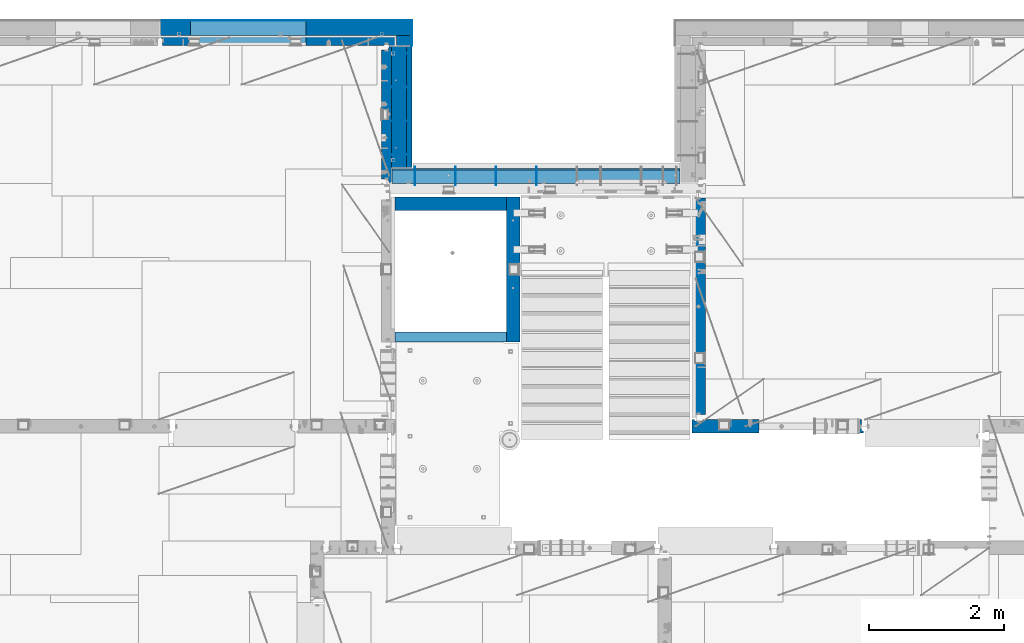
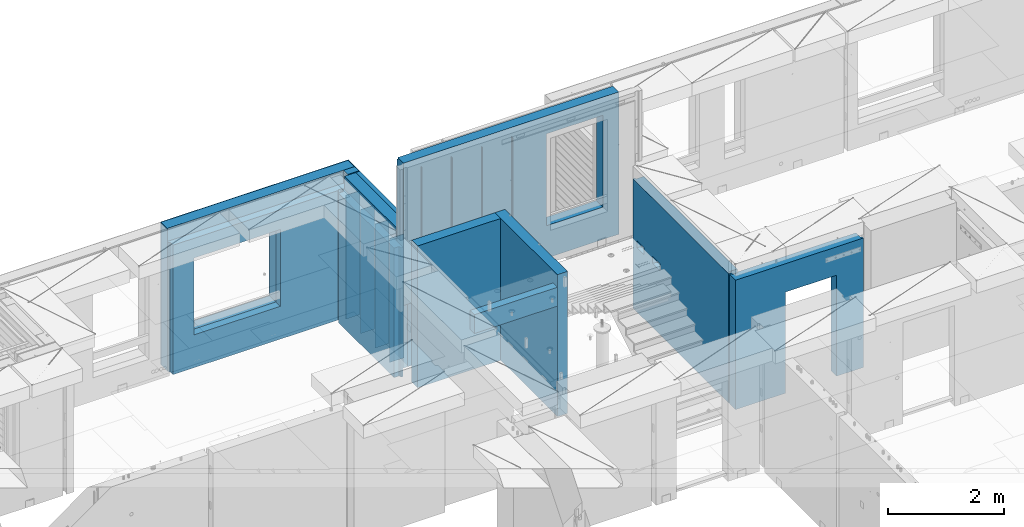
# One storey, part 229 of 341: 22 walls, 7 elements without a shape of their own.
"""IFC2X3 building model written with IfcOpenShell, lengths in millimetres."""

from ifc_helpers import new_model, si_unit, frame, origin_with_axes, place, context, subcontext, project, spatial, faceted_brep, material, type_object, element, aggregate, save


model = new_model("IFC2X3")

# Units and contexts
model_context = context("Model", 3, precision=1e-05, world=origin_with_axes())
body_context = subcontext(model_context, "Body", "Model", "MODEL_VIEW")
ifc_project = project(units=[si_unit("LENGTHUNIT", "METRE", prefix="MILLI"), si_unit("AREAUNIT", "SQUARE_METRE"), si_unit("VOLUMEUNIT", "CUBIC_METRE"), si_unit("MASSUNIT", "GRAM", prefix="KILO"), si_unit("TIMEUNIT", "SECOND"), si_unit("PLANEANGLEUNIT", "RADIAN"), si_unit("SOLIDANGLEUNIT", "STERADIAN"), si_unit("THERMODYNAMICTEMPERATUREUNIT", "DEGREE_CELSIUS"), si_unit("LUMINOUSINTENSITYUNIT", "LUMEN")], contexts=[model_context])

# Site, building, storey
site_placement = place(None, origin_with_axes())
site = spatial("IfcSite", under=ifc_project, at=site_placement, CompositionType="ELEMENT")
building_placement = place(site_placement, origin_with_axes())
building = spatial("IfcBuilding", under=site, at=building_placement, CompositionType="ELEMENT")
storey_placement = place(building_placement, origin_with_axes())
storey = spatial("IfcBuildingStorey", under=building, at=storey_placement, Name="5", CompositionType="ELEMENT", Elevation=0.0)

# Assembly, walls
assembly_1_placement = place(storey_placement, origin_with_axes())
assembly_1 = element("IfcElementAssembly", 1, at=assembly_1_placement, inside=storey, AssemblyPlace="NOTDEFINED", PredefinedType="REINFORCEMENT_UNIT")
ifc_material_1 = material(Name="Undefined")
wall_type_1 = type_object("IfcWallType", PredefinedType="NOTDEFINED")
wall_1_placement = place(assembly_1_placement, frame((17730.0, 21005.0, 95115.0), z_axis=(0.0, 0.0, 1.0), x_axis=(1.0, 0.0, 0.0)))
wall_1 = element("IfcWall", 2, at=wall_1_placement, type_object=wall_type_1, material=ifc_material_1, Name="(PD)", context=body_context, shape_type="Brep", body=[
    faceted_brep([(0.0, 5.0, -1300.0), (0.0, 5.0, 1300.0), (280.0, 5.0, 1300.0), (280.0, 5.0, -1300.0), (0.0, -5.0, 1300.0), (280.0, -5.0, 1300.0), (0.0, -5.0, -1300.0), (280.0, -5.0, -1300.0)], [[[0, 1, 2, 3]], [[1, 4, 5, 2]], [[4, 6, 7, 5]], [[6, 0, 3, 7]], [[5, 7, 3, 2]], [[6, 4, 1, 0]]]),
])
wall_2_placement = place(assembly_1_placement, frame((17730.0, 21505.0, 95115.0), z_axis=(0.0, 0.0, 1.0), x_axis=(1.0, 0.0, 0.0)))
wall_2 = element("IfcWall", 3, at=wall_2_placement, type_object=wall_type_1, material=ifc_material_1, Name="(PD)", context=body_context, shape_type="Brep", body=[
    faceted_brep([(0.0, 5.0, -1300.0), (0.0, 5.0, 1300.0), (280.0, 5.0, 1300.0), (280.0, 5.0, -1300.0), (0.0, -5.0, 1300.0), (280.0, -5.0, 1300.0), (0.0, -5.0, -1300.0), (280.0, -5.0, -1300.0)], [[[0, 1, 2, 3]], [[1, 4, 5, 2]], [[4, 6, 7, 5]], [[6, 0, 3, 7]], [[5, 7, 3, 2]], [[6, 4, 1, 0]]]),
])
wall_3_placement = place(assembly_1_placement, frame((17730.0, 22005.0, 95115.0), z_axis=(0.0, 0.0, 1.0), x_axis=(1.0, 0.0, 0.0)))
wall_3 = element("IfcWall", 4, at=wall_3_placement, type_object=wall_type_1, material=ifc_material_1, Name="(PD)", context=body_context, shape_type="Brep", body=[
    faceted_brep([(0.0, 5.0, -1300.0), (0.0, 5.0, 1300.0), (280.0, 5.0, 1300.0), (280.0, 5.0, -1300.0), (0.0, -5.0, 1300.0), (280.0, -5.0, 1300.0), (0.0, -5.0, -1300.0), (280.0, -5.0, -1300.0)], [[[0, 1, 2, 3]], [[1, 4, 5, 2]], [[4, 6, 7, 5]], [[6, 0, 3, 7]], [[5, 7, 3, 2]], [[6, 4, 1, 0]]]),
])

assembly_2_placement = place(storey_placement, origin_with_axes())
assembly_2 = element("IfcElementAssembly", 5, at=assembly_2_placement, inside=storey, AssemblyPlace="NOTDEFINED", PredefinedType="REINFORCEMENT_UNIT")
wall_4_placement = place(assembly_2_placement, frame((18110.0002441406, 20550.0, 96745.0), z_axis=(0.0, 0.0, 1.0), x_axis=(0.0, 1.0, 0.0)))
wall_4 = element("IfcWall", 6, at=wall_4_placement, type_object=wall_type_1, material=ifc_material_1, Name="(PD)", context=body_context, shape_type="Brep", body=[
    faceted_brep([(0.0, 5.0, -1300.0), (0.0, 5.0, 1300.0), (280.0, 5.0, 1300.0), (280.0, 5.0, -1300.0), (0.0, -5.0, 1300.0), (280.0, -5.0, 1300.0), (0.0, -5.0, -1300.0), (280.0, -5.0, -1300.0)], [[[0, 1, 2, 3]], [[1, 4, 5, 2]], [[4, 6, 7, 5]], [[6, 0, 3, 7]], [[5, 7, 3, 2]], [[6, 4, 1, 0]]]),
])
wall_5_placement = place(assembly_2_placement, frame((18710.0002441406, 20550.0, 96745.0), z_axis=(0.0, 0.0, 1.0), x_axis=(0.0, 1.0, 0.0)))
wall_5 = element("IfcWall", 7, at=wall_5_placement, type_object=wall_type_1, material=ifc_material_1, Name="(PD)", context=body_context, shape_type="Brep", body=[
    faceted_brep([(0.0, 5.0, -1300.0), (0.0, 5.0, 1300.0), (280.0, 5.0, 1300.0), (280.0, 5.0, -1300.0), (0.0, -5.0, 1300.0), (280.0, -5.0, 1300.0), (0.0, -5.0, -1300.0), (280.0, -5.0, -1300.0)], [[[0, 1, 2, 3]], [[1, 4, 5, 2]], [[4, 6, 7, 5]], [[6, 0, 3, 7]], [[5, 7, 3, 2]], [[6, 4, 1, 0]]]),
])
wall_6_placement = place(assembly_2_placement, frame((19310.0002441406, 20550.0, 96745.0), z_axis=(0.0, 0.0, 1.0), x_axis=(0.0, 1.0, 0.0)))
wall_6 = element("IfcWall", 8, at=wall_6_placement, type_object=wall_type_1, material=ifc_material_1, Name="(PD)", context=body_context, shape_type="Brep", body=[
    faceted_brep([(0.0, 5.0, -1300.0), (0.0, 5.0, 1300.0), (280.0, 5.0, 1300.0), (280.0, 5.0, -1300.0), (0.0, -5.0, 1300.0), (280.0, -5.0, 1300.0), (0.0, -5.0, -1300.0), (280.0, -5.0, -1300.0)], [[[0, 1, 2, 3]], [[1, 4, 5, 2]], [[4, 6, 7, 5]], [[6, 0, 3, 7]], [[5, 7, 3, 2]], [[6, 4, 1, 0]]]),
])
wall_7_placement = place(assembly_2_placement, frame((19910.0002441406, 20550.0, 96745.0), z_axis=(0.0, 0.0, 1.0), x_axis=(0.0, 1.0, 0.0)))
wall_7 = element("IfcWall", 9, at=wall_7_placement, type_object=wall_type_1, material=ifc_material_1, Name="(PD)", context=body_context, shape_type="Brep", body=[
    faceted_brep([(0.0, 5.0, -1300.0), (0.0, 5.0, 1300.0), (280.0, 5.0, 1300.0), (280.0, 5.0, -1300.0), (0.0, -5.0, 1300.0), (280.0, -5.0, 1300.0), (0.0, -5.0, -1300.0), (280.0, -5.0, -1300.0)], [[[0, 1, 2, 3]], [[1, 4, 5, 2]], [[4, 6, 7, 5]], [[6, 0, 3, 7]], [[5, 7, 3, 2]], [[6, 4, 1, 0]]]),
])

# Wall
wall_8_placement = place(assembly_1_placement, frame((17730.0, 22505.0, 95115.0), z_axis=(0.0, 0.0, 1.0), x_axis=(1.0, 0.0, 0.0)))
wall_8 = element("IfcWall", 10, at=wall_8_placement, type_object=wall_type_1, material=ifc_material_1, Name="(PD)", context=body_context, shape_type="Brep", body=[
    faceted_brep([(0.0, 5.0, -1300.0), (0.0, 5.0, 1300.0), (280.0, 5.0, 1300.0), (280.0, 5.0, -1300.0), (0.0, -5.0, 1300.0), (280.0, -5.0, 1300.0), (0.0, -5.0, -1300.0), (280.0, -5.0, -1300.0)], [[[0, 1, 2, 3]], [[1, 4, 5, 2]], [[4, 6, 7, 5]], [[6, 0, 3, 7]], [[5, 7, 3, 2]], [[6, 4, 1, 0]]]),
])

# Assembly, wall
assembly_3_placement = place(storey_placement, origin_with_axes())
assembly_3 = element("IfcElementAssembly", 11, at=assembly_3_placement, inside=storey, AssemblyPlace="NOTDEFINED", PredefinedType="REINFORCEMENT_UNIT")
ifc_material_2 = material(Name="CONCRETE/C25/30")
wall_type_2 = type_object("IfcWallType", PredefinedType="NOTDEFINED")
wall_9_placement = place(assembly_3_placement, frame((22310.0, 16980.0, 95112.5), z_axis=(0.0, 0.0, 1.0), x_axis=(1.0, 0.0, 0.0)))
wall_9 = element("IfcWall", 12, at=wall_9_placement, type_object=wall_type_2, material=ifc_material_2, context=body_context, shape_type="Brep", body=[
    faceted_brep([(890.000686645508, 100.0, 762.5), (890.000686645508, -100.0, 762.5), (890.000686645508, -100.0, -1357.5), (890.000686645508, 100.0, -1357.5), (1910.00068664551, 100.0, 762.5), (1910.00068664551, -100.0, 762.5), (1910.00068664551, 100.0, -1357.5), (1910.00068664551, -100.0, -1357.5), (-100.0, -100.0, -1357.5), (-100.0, -100.0, 1357.5), (-100.0, 100.0, 1357.5), (-100.0, 100.0, -1357.5), (2440.0, -100.0, 1357.5), (2440.0, -100.0, -1357.5), (2440.0, -70.0000000000036, -1357.5), (2440.0, -70.0000000000036, 1357.5), (2410.0, 100.0, 1357.5), (2410.0, -57.0, 1357.5), (2410.0, -57.0, -1357.5), (2410.0, 100.0, -1357.5), (65.0000000000036, 100.0, 1357.5), (52.0, 80.0, 1357.5), (-52.0, 80.0, 1357.5), (-65.0, 100.0, 1357.5), (-65.0, 100.0, -1357.5), (-52.0, 80.0, -1357.5), (52.0, 80.0, -1357.5), (65.0000000000036, 100.0, -1357.5)], [[[0, 1, 2, 3]], [[4, 5, 1, 0]], [[6, 7, 5, 4]], [[8, 9, 10, 11]], [[12, 13, 14, 15]], [[16, 17, 18, 19]], [[15, 14, 18, 17]], [[16, 20, 21, 22, 23, 10, 9, 12, 15, 17]], [[11, 10, 23, 24]], [[22, 25, 24, 23]], [[21, 26, 25, 22]], [[20, 27, 26, 21]], [[8, 11, 24, 25, 26, 27, 3, 2]], [[13, 12, 9, 8, 2, 1, 5, 7]], [[19, 18, 14, 13, 7, 6]], [[3, 27, 20, 16, 19, 6, 4, 0]]]),
])
aggregate(assembly_3, [wall_9])

assembly_4_placement = place(storey_placement, origin_with_axes())
assembly_4 = element("IfcElementAssembly", 13, at=assembly_4_placement, inside=storey, AssemblyPlace="NOTDEFINED", PredefinedType="REINFORCEMENT_UNIT")
wall_10_placement = place(assembly_4_placement, frame((22310.0, 16980.0, 95112.5), z_axis=(0.0, 0.0, 1.0), x_axis=(0.0, 1.0, 0.0)))
wall_10 = element("IfcWall", 14, at=wall_10_placement, type_object=wall_type_2, material=ifc_material_2, context=body_context, shape_type="Brep", body=[
    faceted_brep([(3059.9952678883, 0.0998642726626713, 102.5), (3259.9952678883, 0.0998642726626713, 102.5), (3259.9952678883, 0.0998642726626713, -7.5), (3059.9952678883, 0.0998642726626713, -7.5), (3034.9952678883, 100.099864272663, -7.5), (3284.9952678883, 100.099864272663, -7.5), (3034.9952678883, 100.099864272663, 137.5), (3284.9952678883, 100.099864272663, 137.5), (3420.0, 70.0, 1357.5), (3420.0, 100.0, 1357.5), (130.0, 100.0, 1357.5), (130.0, 70.0, 1357.5), (180.0, 57.0, 1357.5), (180.0, -100.0, 1357.5), (3384.99999178648, -100.000000948603, 1357.5), (3385.00000172571, 57.0000007519884, 1357.5), (130.0, 100.0, -1357.5), (130.0, 70.0, -1357.5), (180.0, 57.0, -1357.5), (180.0, -100.0, -1357.5), (3384.99999178648, -100.0, -1357.5), (3385.00000172571, 57.0000007519884, -1357.5), (3420.0, 100.0, -1357.5), (3420.0, 70.0, -1357.5), (2519.9952678883, 0.0998642726626713, 102.5), (2719.9952678883, 0.0998642726626713, 102.5), (2719.9952678883, 0.0998642726626713, -7.5), (2519.9952678883, 0.0998642726626713, -7.5), (2744.9952678883, 100.099864272663, -7.5), (2744.9952678883, 100.099864272663, 137.5), (2494.9952678883, 100.099864272663, -7.5), (2494.9952678883, 100.099864272663, 137.5)], [[[0, 1, 2, 3]], [[4, 3, 2, 5]], [[6, 0, 3, 4]], [[7, 1, 0, 6]], [[5, 2, 1, 7]], [[8, 9, 10, 11, 12, 13, 14, 15]], [[10, 16, 17, 11]], [[11, 17, 18, 12]], [[13, 12, 18, 19]], [[13, 19, 20, 14]], [[14, 20, 21, 15]], [[19, 18, 17, 16, 22, 23, 21, 20]], [[15, 21, 23, 8]], [[22, 9, 8, 23]], [[24, 25, 26, 27]], [[28, 26, 25, 29]], [[30, 27, 26, 28]], [[31, 24, 27, 30]], [[29, 25, 24, 31]], [[16, 10, 9, 22], [4, 5, 7, 6], [30, 28, 29, 31]]]),
])
aggregate(assembly_4, [wall_10])

# Assembly
assembly_5_placement = place(assembly_2_placement, origin_with_axes())
assembly_5 = element("IfcElementAssembly", 15, at=assembly_5_placement, Name="Steel Assembly", AssemblyPlace="NOTDEFINED", PredefinedType="NOTDEFINED")

aggregate(assembly_2, [assembly_5, wall_4, wall_5, wall_6, wall_7])

# Wall
ifc_material_3 = material(Name="COS5gt")
wall_type_3 = type_object("IfcWallType", PredefinedType="NOTDEFINED")
wall_11_placement = place(assembly_5_placement, frame((17765.0, 20690.0, 96747.5), z_axis=(0.0, 0.0, 1.0), x_axis=(1.0, 0.0, 0.0)))
wall_11 = element("IfcWall", 16, at=wall_11_placement, type_object=wall_type_3, material=ifc_material_3, context=body_context, shape_type="Brep", body=[
    faceted_brep([(0.0, -110.0, 1492.5), (4270.0, -110.0, 1492.5), (4270.0, 90.0, 1492.5), (0.0, 90.0, 1492.5), (4270.0, 110.0, 1442.5), (4270.0, 90.0, 1442.5), (4270.0, -110.0, -1492.5), (4270.0, 90.0, -1492.5), (4270.0, 90.0, -1442.5), (4270.0, 110.0, -1442.5), (0.0, 110.0, 1442.5), (0.0, 110.0, -1442.5), (2839.99840497971, 109.999997720995, -802.5), (2839.99840497971, 109.999997720995, -807.5), (2869.99840497971, 109.999997720995, -807.5), (3919.99840497971, 109.999997720995, -807.5), (3949.99840497971, 109.999997720995, -807.5), (3949.99840497971, 109.999997720995, -802.5), (3949.99840497971, 109.999997720995, 1107.5), (2839.99840497971, 109.999997720995, 1107.5), (2834.05245909535, -110.0, 1113.44594588435), (3955.94435086406, -110.0, 1113.44594588435), (2834.05245909535, -110.0, -813.445945884348), (3955.94435086406, -110.0, -813.445945884348), (0.0, -110.0, -1492.5), (0.0, 90.0, -1492.5), (0.0, 90.0, -1442.5), (0.0, 90.0, 1442.5)], [[[0, 1, 2, 3]], [[4, 5, 2, 1, 6, 7, 8, 9]], [[10, 4, 9, 11], [12, 13, 14, 15, 16, 17, 18, 19]], [[20, 19, 18, 21]], [[12, 19, 20, 22, 13]], [[23, 16, 15, 14, 13, 22]], [[21, 18, 17, 16, 23]], [[0, 24, 6, 1], [22, 20, 21, 23]], [[6, 24, 25, 7]], [[7, 25, 26, 8]], [[9, 8, 26, 11]], [[25, 24, 0, 3, 27, 10, 11, 26]], [[2, 5, 27, 3]], [[4, 10, 27, 5]]]),
])

aggregate(assembly_5, [wall_11])

wall_12_placement = place(assembly_1_placement, frame((17870.0, 22605.0, 95247.5), z_axis=(0.0, 0.0, 1.0), x_axis=(0.0, -1.0, 0.0)))
wall_12 = element("IfcWall", 17, at=wall_12_placement, type_object=wall_type_3, material=ifc_material_3, context=body_context, shape_type="Brep", body=[
    faceted_brep([(0.0, 110.0, -1492.5), (0.0, 110.0, 1492.5), (1790.0, 110.0, 1492.5), (1790.0, 110.0, -1492.5), (0.0, -110.0, 1492.5), (1790.0, -110.0, 1492.5), (0.0, -110.0, -1492.5), (1790.0, -110.0, -1492.5)], [[[0, 1, 2, 3]], [[1, 4, 5, 2]], [[4, 6, 7, 5]], [[6, 0, 3, 7]], [[5, 7, 3, 2]], [[6, 4, 1, 0]]]),
])

# Assembly, walls
assembly_6_placement = place(storey_placement, origin_with_axes())
assembly_6 = element("IfcElementAssembly", 18, at=assembly_6_placement, inside=storey, AssemblyPlace="NOTDEFINED", PredefinedType="REINFORCEMENT_UNIT")
ifc_material_4 = material()
wall_13_placement = place(assembly_6_placement, frame((17945.0, 22770.0, 95247.5), z_axis=(0.0, 0.0, 1.0), x_axis=(0.0, -1.0, 0.0)))
wall_13 = element("IfcWall", 19, at=wall_13_placement, type_object=wall_type_3, material=ifc_material_4, context=body_context, shape_type="Brep", body=[
    faceted_brep([(0.0, 110.0, -1492.5), (0.0, 110.0, 1492.5), (150.0, 110.0, 1492.5), (150.0, 110.0, -1492.5), (0.0, -110.0, 1492.5), (150.0, -110.0, 1492.5), (0.0, -110.0, -1492.5), (150.0, -110.0, -1492.5)], [[[0, 1, 2, 3]], [[1, 4, 5, 2]], [[4, 6, 7, 5]], [[6, 0, 3, 7]], [[5, 7, 3, 2]], [[6, 4, 1, 0]]]),
])
wall_14_placement = place(assembly_6_placement, frame((14340.0, 22880.0, 95247.5), z_axis=(0.0, 0.0, 1.0), x_axis=(1.0, 0.0, 0.0)))
wall_14 = element("IfcWall", 20, at=wall_14_placement, type_object=wall_type_3, material=ifc_material_4, context=body_context, shape_type="Brep", body=[
    faceted_brep([(0.0, -110.0, -1492.5), (0.0, 110.0, -1492.5), (3715.0, 110.0, -1492.5), (3715.0, -110.0, -1492.5), (0.0, -110.0, 1492.5), (0.0, 110.0, 1492.5), (3715.0, -110.0, 1492.5), (3715.0, 110.0, 1492.5), (444.999710731721, 110.0, -802.5), (2154.99971073172, 110.0, -802.5), (2154.99971073172, 110.0, 807.5), (444.999710731721, 110.0, 807.5), (444.999710731721, -110.0, -802.5), (444.999710731721, -110.0, 807.5), (2154.99971073172, -110.0, 807.5), (2154.99971073172, -110.0, -802.5)], [[[0, 1, 2, 3]], [[0, 4, 5, 1]], [[5, 4, 6, 7]], [[1, 5, 7, 2], [8, 9, 10, 11]], [[6, 3, 2, 7]], [[4, 0, 3, 6], [12, 13, 14, 15]], [[10, 14, 13, 11]], [[9, 15, 14, 10]], [[8, 12, 15, 9]], [[11, 13, 12, 8]]]),
])

# Wall
ifc_material_5 = material(Name="CONCRETE/C30/37")
wall_type_4 = type_object("IfcWallType", PredefinedType="NOTDEFINED")
wall_15_placement = place(assembly_1_placement, frame((18022.5, 22620.0, 95247.5), z_axis=(0.0, 0.0, 1.0), x_axis=(0.0, -1.0, 0.0)))
wall_15 = element("IfcWall", 21, at=wall_15_placement, type_object=wall_type_4, material=ifc_material_5, context=body_context, shape_type="Brep", body=[
    faceted_brep([(15.0, 42.5, 1342.99999994476), (15.0, 32.4999992506928, 1344.9999999992), (1805.0, 32.5, 1345.0), (1805.0, 42.5, 1343.0), (15.0, 32.4999991126933, 1355.00000040043), (1805.0, 32.5, 1355.0), (15.0, 42.5, 1356.99999988925), (1805.0, 42.5, 1357.0), (15.0, 42.5, 1206.99999988925), (1805.0, 42.5, 1207.0), (1805.0, 32.5, 1205.0), (15.0000000000009, 32.4999991126933, 1205.00000040043), (1805.0, 32.5, 1195.0), (15.0000000000009, 32.4999992506928, 1194.9999999992), (15.0, 42.5, 1192.99999994476), (1805.0, 42.5, 1193.0), (1805.0, 42.5, 1057.0), (15.0, 42.5, 1056.99999988925), (1805.0, 32.5, 1055.0), (15.0, 32.4999991126933, 1055.00000040043), (1805.0, 32.5, 1045.0), (15.0, 32.4999992506928, 1044.9999999992), (15.0, 42.5, 1042.99999994476), (1805.0, 42.5, 1043.0), (1805.0, 42.5, 907.0), (15.0, 42.5, 906.999999889245), (1805.0, 32.5, 905.0), (15.0, 32.4999991126933, 905.000000400425), (1805.0, 32.5, 895.0), (15.0, 32.4999992506928, 894.9999999992), (15.0, 42.5, 892.999999944761), (1805.0, 42.5, 893.0), (1805.0, 42.5, 757.0), (15.0, 42.5, 756.999999889245), (1805.0, 32.5, 755.0), (15.0, 32.4999991126933, 755.000000400425), (1805.0, 32.5, 745.0), (15.0, 32.4999992506928, 744.9999999992), (15.0, 42.5, 742.999999944761), (1805.0, 42.5, 743.0), (1805.0, 42.5, 607.0), (15.0, 42.5, 606.999999889245), (1805.0, 32.5, 605.0), (15.0, 32.4999991126933, 605.000000400425), (1805.0, 32.5, 595.0), (15.0, 32.4999992506928, 594.9999999992), (15.0, 42.5, 592.999999944761), (1805.0, 42.5, 593.0), (1805.0, 42.5, 457.0), (15.0, 42.5, 456.999999889245), (1805.0, 32.5, 455.0), (15.0, 32.4999991126933, 455.000000400425), (1805.0, 32.5, 445.0), (15.0, 32.4999992506928, 444.9999999992), (15.0, 42.5, 442.999999944761), (1805.0, 42.5, 443.0), (1805.0, 42.5, 307.0), (15.0, 42.5, 306.999999889245), (1805.0, 32.5, 305.0), (15.0, 32.4999991126933, 305.000000400425), (1805.0, 32.5, 295.0), (15.0, 32.4999992506928, 294.9999999992), (15.0, 42.5, 292.999999944761), (1805.0, 42.5, 293.0), (1805.0, 42.5, 157.0), (15.0, 42.5, 156.999999889245), (1805.0, 32.5, 155.0), (15.0000000000009, 32.4999991126933, 155.000000400425), (1805.0, 32.5, 145.0), (15.0000000000009, 32.4999992506928, 144.9999999992), (15.0, 42.5, 142.999999944761), (1805.0, 42.5, 143.0), (1805.0, 42.5, 7.0), (15.0, 42.5, 6.99999988924537), (1805.0, 32.5, 5.0), (14.9999999999991, 32.4999991126933, 5.00000040042505), (1805.0, 32.5, -5.0), (14.9999999999991, 32.4999992506928, -5.00000000080036), (15.0, 42.5, -7.00000005523907), (1805.0, 42.5, -7.0), (1805.0, 42.5, -143.0), (15.0, 42.5, -143.000000110755), (1805.0, 32.5, -145.0), (15.0000000000009, 32.4999991126933, -144.999999599575), (1805.0, 32.5, -155.0), (15.0000000000009, 32.4999992506928, -155.0000000008), (15.0, 42.5, -157.000000055239), (1805.0, 42.5, -157.0), (1805.0, 42.5, -293.0), (15.0, 42.5, -293.000000110755), (1805.0, 32.5, -295.0), (15.0, 32.4999991126933, -294.999999599575), (1805.0, 32.5, -305.0), (15.0, 32.4999992506928, -305.0000000008), (15.0, 42.5, -307.000000055239), (1805.0, 42.5, -307.0), (1805.0, 42.5, -443.0), (15.0, 42.5, -443.000000110755), (1805.0, 32.5, -445.0), (15.0000000000009, 32.4999991126933, -444.999999599575), (1805.0, 32.5, -455.0), (15.0000000000009, 32.4999992506928, -455.0000000008), (15.0, 42.5, -457.000000055239), (1805.0, 42.5, -457.0), (1805.0, 42.5, -593.0), (15.0, 42.5, -593.000000110755), (1805.0, 32.5, -595.0), (15.0, 32.4999991126933, -594.999999599575), (1805.0, 32.5, -605.0), (15.0, 32.4999992506928, -605.0000000008), (15.0, 42.5, -607.000000055239), (1805.0, 42.5, -607.0), (1805.0, 42.5, -743.0), (15.0, 42.5, -743.000000110755), (1805.0, 32.5, -745.0), (15.0, 32.4999991126933, -744.999999599575), (1805.0, 32.5, -755.0), (15.0, 32.4999992506928, -755.0000000008), (15.0, 42.5, -757.000000055239), (1805.0, 42.5, -757.0), (1805.0, 42.5, -893.0), (15.0, 42.5, -893.000000110755), (1805.0, 32.5, -895.0), (15.0000000000009, 32.4999991126933, -894.999999599575), (1805.0, 32.5, -905.0), (15.0000000000009, 32.4999992506928, -905.0000000008), (15.0, 42.5, -907.000000055239), (1805.0, 42.5, -907.0), (1805.0, 42.5, -1043.0), (15.0, 42.5, -1043.00000011075), (1805.0, 32.5, -1045.0), (15.0, 32.4999991126933, -1044.99999959957), (1805.0, 32.5, -1055.0), (15.0, 32.4999992506928, -1055.0000000008), (15.0, 42.5, -1057.00000005524), (1805.0, 42.5, -1057.0), (1805.0, 42.5, -1193.0), (15.0, 42.5, -1193.00000011075), (1805.0, 32.5, -1195.0), (15.0, 32.4999991126933, -1194.99999959957), (1805.0, 32.5, -1205.0), (15.0, 32.4999992506928, -1205.0000000008), (15.0, 42.5, -1207.00000005524), (1805.0, 42.5, -1207.0), (1805.0, 42.5, -1343.0), (15.0, 42.5, -1343.00000011075), (1805.0, 32.5, -1345.0), (15.0, 32.4999991126933, -1344.99999959957), (1805.0, 32.5, -1355.0), (15.0, 32.4999992506928, -1355.0000000008), (15.0, 42.5, -1357.00000005524), (1805.0, 42.5, -1357.0), (1805.0, 42.5, -1492.5), (15.0, 42.5, -1492.5), (15.0, -42.5, -1492.5), (1805.0, -42.5, -1492.5), (15.0, -42.5, 1492.5), (1805.0, -42.5, 1492.5), (15.0, 42.5, 1492.5), (1805.0, 42.5, 1492.5)], [[[0, 1, 2, 3]], [[4, 5, 2, 1]], [[6, 7, 5, 4]], [[8, 9, 10, 11]], [[11, 10, 12, 13]], [[14, 13, 12, 15]], [[16, 17, 14, 15]], [[17, 16, 18, 19]], [[19, 18, 20, 21]], [[22, 21, 20, 23]], [[24, 25, 22, 23]], [[25, 24, 26, 27]], [[27, 26, 28, 29]], [[30, 29, 28, 31]], [[32, 33, 30, 31]], [[33, 32, 34, 35]], [[35, 34, 36, 37]], [[38, 37, 36, 39]], [[40, 41, 38, 39]], [[41, 40, 42, 43]], [[43, 42, 44, 45]], [[46, 45, 44, 47]], [[48, 49, 46, 47]], [[49, 48, 50, 51]], [[51, 50, 52, 53]], [[54, 53, 52, 55]], [[56, 57, 54, 55]], [[57, 56, 58, 59]], [[59, 58, 60, 61]], [[62, 61, 60, 63]], [[64, 65, 62, 63]], [[65, 64, 66, 67]], [[67, 66, 68, 69]], [[70, 69, 68, 71]], [[72, 73, 70, 71]], [[73, 72, 74, 75]], [[75, 74, 76, 77]], [[78, 77, 76, 79]], [[80, 81, 78, 79]], [[81, 80, 82, 83]], [[83, 82, 84, 85]], [[86, 85, 84, 87]], [[88, 89, 86, 87]], [[89, 88, 90, 91]], [[91, 90, 92, 93]], [[94, 93, 92, 95]], [[96, 97, 94, 95]], [[97, 96, 98, 99]], [[99, 98, 100, 101]], [[102, 101, 100, 103]], [[104, 105, 102, 103]], [[105, 104, 106, 107]], [[107, 106, 108, 109]], [[110, 109, 108, 111]], [[112, 113, 110, 111]], [[113, 112, 114, 115]], [[115, 114, 116, 117]], [[118, 117, 116, 119]], [[120, 121, 118, 119]], [[121, 120, 122, 123]], [[123, 122, 124, 125]], [[126, 125, 124, 127]], [[128, 129, 126, 127]], [[129, 128, 130, 131]], [[131, 130, 132, 133]], [[134, 133, 132, 135]], [[136, 137, 134, 135]], [[137, 136, 138, 139]], [[139, 138, 140, 141]], [[142, 141, 140, 143]], [[144, 145, 142, 143]], [[145, 144, 146, 147]], [[147, 146, 148, 149]], [[150, 149, 148, 151]], [[152, 153, 150, 151]], [[154, 153, 152, 155]], [[156, 154, 155, 157]], [[158, 156, 157, 159]], [[1, 0, 8, 11, 13, 14, 17, 19, 21, 22, 25, 27, 29, 30, 33, 35, 37, 38, 41, 43, 45, 46, 49, 51, 53, 54, 57, 59, 61, 62, 65, 67, 69, 70, 73, 75, 77, 78, 81, 83, 85, 86, 89, 91, 93, 94, 97, 99, 101, 102, 105, 107, 109, 110, 113, 115, 117, 118, 121, 123, 125, 126, 129, 131, 133, 134, 137, 139, 141, 142, 145, 147, 149, 150, 153, 154, 156, 158, 6, 4]], [[9, 8, 0, 3]], [[159, 157, 155, 152, 151, 148, 146, 144, 143, 140, 138, 136, 135, 132, 130, 128, 127, 124, 122, 120, 119, 116, 114, 112, 111, 108, 106, 104, 103, 100, 98, 96, 95, 92, 90, 88, 87, 84, 82, 80, 79, 76, 74, 72, 71, 68, 66, 64, 63, 60, 58, 56, 55, 52, 50, 48, 47, 44, 42, 40, 39, 36, 34, 32, 31, 28, 26, 24, 23, 20, 18, 16, 15, 12, 10, 9, 3, 2, 5, 7]], [[158, 159, 7, 6]]]),
])

wall_type_5 = type_object("IfcWallType", PredefinedType="NOTDEFINED")
wall_16_placement = place(assembly_6_placement, frame((14340.0, 22695.0, 95112.5), z_axis=(0.0, 0.0, 1.0), x_axis=(1.0, 0.0, 0.0)))
wall_16 = element("IfcWall", 22, at=wall_16_placement, type_object=wall_type_5, material=ifc_material_2, context=body_context, shape_type="Brep", body=[
    faceted_brep([(444.999710731721, 75.0, 942.5), (444.999710731721, -75.0, 942.5), (444.999710731721, -75.0, -667.5), (444.999710731721, 75.0, -667.5), (2154.99971073172, -75.0, -667.5), (2154.99971073172, 75.0, -667.5), (2154.99971073172, -75.0, 942.5), (2154.99971073172, 75.0, 942.5), (3305.0, -75.0, 1357.5), (3318.00000041054, -54.9999993903439, 1357.5), (3372.00000031511, -54.9999994175341, 1357.5), (3385.00000278453, -75.0000022791319, 1357.5), (3495.0, -75.0, 1357.5), (3495.0, 75.0, 1357.5), (0.0, 75.0, 1357.5), (0.0, 45.0, 1357.5), (30.0000010550393, 24.9999970131248, 1357.5), (30.0000016637459, -75.0, 1357.5), (3305.0, -75.0, -1357.5), (3318.00000041054, -54.9999993903439, -1357.5), (3372.00000031511, -54.9999994175341, -1357.5), (3385.00000278453, -75.0, -1357.5), (3495.0, -75.0, -1357.5), (3495.0, 75.0, -1357.5), (0.0, 75.0, -1357.5), (0.0, 45.0, -1357.5), (30.0000010550393, 24.9999970131248, -1357.49999999999), (30.0000016637459, -75.0, -1357.5)], [[[0, 1, 2, 3]], [[3, 2, 4, 5]], [[5, 4, 6, 7]], [[7, 6, 1, 0]], [[8, 9, 10, 11, 12, 13, 14, 15, 16, 17]], [[8, 18, 19, 9]], [[9, 19, 20, 10]], [[11, 10, 20, 21]], [[22, 12, 11, 21]], [[12, 22, 23, 13]], [[24, 14, 13, 23], [3, 5, 7, 0]], [[14, 24, 25, 15]], [[15, 25, 26, 16]], [[24, 23, 22, 21, 20, 19, 18, 27, 26, 25]], [[16, 26, 27, 17]], [[18, 8, 17, 27], [2, 1, 6, 4]]]),
])

wall_17_placement = place(assembly_1_placement, frame((17685.0, 22605.0, 95112.5), z_axis=(0.0, 0.0, 1.0), x_axis=(0.0, -1.0, 0.0)))
wall_17 = element("IfcWall", 23, at=wall_17_placement, type_object=wall_type_5, material=ifc_material_2, context=body_context, shape_type="Brep", body=[
    faceted_brep([(1959.99999772087, -75.0, 1357.5), (1959.99999772087, -75.0, -1357.5), (1959.99999772087, 27.0, -1357.5), (1959.99999772087, 27.0, 1357.5), (2009.99999772087, 40.0, -1357.5), (2009.99999772087, 40.0, 1357.5), (50.0, -75.0, 1357.5), (50.0, 27.0, 1357.5), (50.0, 27.0, -1357.5), (50.0, -75.0, -1357.5), (0.0, 40.0, 1357.5), (0.0, 40.0, -1357.5), (0.0, 75.0, 1357.5), (0.0, 75.0, -1357.5), (2009.99999772087, 75.0, 1357.5), (2009.99999772087, 75.0, -1357.5)], [[[0, 1, 2, 3]], [[3, 2, 4, 5]], [[6, 7, 8, 9]], [[10, 11, 8, 7]], [[12, 13, 11, 10]], [[13, 12, 14, 15]], [[15, 14, 5, 4]], [[11, 13, 15, 4, 2, 1, 9, 8]], [[1, 0, 6, 9]], [[0, 3, 5, 14, 12, 10, 7, 6]]]),
])

aggregate(assembly_1, [wall_12, wall_1, wall_2, wall_3, wall_8, wall_15, wall_17])

# Assembly, walls
assembly_7_placement = place(storey_placement, origin_with_axes())
assembly_7 = element("IfcElementAssembly", 24, at=assembly_7_placement, inside=storey, AssemblyPlace="NOTDEFINED", PredefinedType="REINFORCEMENT_UNIT")
wall_type_6 = type_object("IfcWallType", PredefinedType="NOTDEFINED")
wall_18_placement = place(assembly_7_placement, frame((17809.9999105288, 20280.0000293051, 95242.5), z_axis=(0.0, 0.0, 1.0), x_axis=(1.0, 0.0, 0.0)))
wall_18 = element("IfcWall", 25, at=wall_18_placement, type_object=wall_type_6, material=ifc_material_2, context=body_context, shape_type="Brep", body=[
    faceted_brep([(0.0, 100.0, -1487.5), (0.0, 100.0, 1487.5), (1649.99977111816, 100.0, 1487.5), (1649.99977111816, 100.0, -1487.5), (0.0, -100.0, 1487.5), (1649.99977111816, -100.0, 1487.5), (0.0, -100.0, -1487.5), (1649.99977111816, -100.0, -1487.5)], [[[0, 1, 2, 3]], [[1, 4, 5, 2]], [[4, 6, 7, 5]], [[6, 0, 3, 7]], [[5, 7, 3, 2]], [[6, 4, 1, 0]]]),
])
wall_19_placement = place(assembly_7_placement, frame((19559.999681647, 18229.9992663657, 95242.5), z_axis=(0.0, 0.0, 1.0), x_axis=(0.0, 1.0, 0.0)))
wall_19 = element("IfcWall", 26, at=wall_19_placement, type_object=wall_type_6, material=ifc_material_2, context=body_context, shape_type="Brep", body=[
    faceted_brep([(1470.00546574604, -0.100182625668822, -27.5), (1270.00546574604, -0.100182625668822, -27.5), (1270.00546574604, -0.100182625668822, -137.5), (1470.00546574604, -0.100182625668822, -137.5), (1245.00546574604, -100.100182625669, -137.5), (1245.00546574604, -100.100182625669, 7.5), (1495.00546574604, -100.100182625669, -137.5), (1495.00546574604, -100.100182625669, 7.5), (0.0, -100.0, -1487.5), (0.0, 100.0, -1487.5), (2150.00073363433, 100.0, -1487.5), (2150.00073363433, -100.0, -1487.5), (0.0, -100.0, 1487.5), (0.0, 100.0, 1487.5), (2150.00073363433, -100.0, 1487.5), (2150.00073363433, 100.0, 1487.5), (2010.00546574604, -0.100182625668822, -27.5), (1810.00546574604, -0.100182625668822, -27.5), (1810.00546574604, -0.100182625668822, -137.5), (2010.00546574604, -0.100182625668822, -137.5), (1785.00546574604, -100.100182625669, 7.5), (2035.00546574604, -100.100182625669, 7.5), (1785.00546574604, -100.100182625669, -137.5), (2035.00546574604, -100.100182625669, -137.5)], [[[0, 1, 2, 3]], [[4, 2, 1, 5]], [[6, 3, 2, 4]], [[7, 0, 3, 6]], [[5, 1, 0, 7]], [[8, 9, 10, 11]], [[8, 12, 13, 9]], [[13, 12, 14, 15]], [[9, 13, 15, 10]], [[14, 11, 10, 15]], [[16, 17, 18, 19]], [[20, 17, 16, 21]], [[22, 18, 17, 20]], [[23, 19, 18, 22]], [[21, 16, 19, 23]], [[12, 8, 11, 14], [4, 5, 7, 6], [22, 20, 21, 23]]]),
])
wall_type_7 = type_object("IfcWallType", PredefinedType="NOTDEFINED")
wall_20_placement = place(assembly_7_placement, frame((17809.9999105288, 18304.9992663657, 96272.5), z_axis=(0.0, 0.0, 1.0), x_axis=(1.0, 0.0, 0.0)))
wall_20 = element("IfcWall", 27, at=wall_20_placement, type_object=wall_type_7, material=ifc_material_2, context=body_context, shape_type="Brep", body=[
    faceted_brep([(0.0, 75.0, -197.5), (0.0, 75.0, 197.5), (1649.99961853027, 75.0, 197.5), (1649.99961853027, 75.0, -197.5), (0.0, -75.0, 197.5), (1649.99961853027, -75.0, 197.5), (0.0, -75.0, -197.5), (1649.99961853027, -75.0, -197.5)], [[[0, 1, 2, 3]], [[1, 4, 5, 2]], [[4, 6, 7, 5]], [[6, 0, 3, 7]], [[5, 7, 3, 2]], [[6, 4, 1, 0]]]),
])
aggregate(assembly_7, [wall_18, wall_20, wall_19])

# Wall
wall_type_8 = type_object("IfcWallType", PredefinedType="NOTDEFINED")
wall_21_placement = place(assembly_6_placement, frame((18060.0, 22990.0, 95247.5), z_axis=(0.0, 0.0, 1.0), x_axis=(0.0, -1.0, 0.0)))
wall_21 = element("IfcWall", 28, at=wall_21_placement, type_object=wall_type_8, material=ifc_material_5, context=body_context, shape_type="Brep", body=[
    faceted_brep([(0.0, 5.0, -1492.5), (0.0, 5.0, 1492.5), (370.0, 5.0, 1492.5), (370.0, 5.0, -1492.5), (0.0, -5.0, 1492.5), (370.0, -5.0, 1492.5), (0.0, -5.0, -1492.5), (370.0, -5.0, -1492.5)], [[[0, 1, 2, 3]], [[1, 4, 5, 2]], [[4, 6, 7, 5]], [[6, 0, 3, 7]], [[5, 7, 3, 2]], [[6, 4, 1, 0]]]),
])

wall_22_placement = place(assembly_6_placement, frame((14340.0, 22995.0, 95247.5), z_axis=(0.0, 0.0, 1.0), x_axis=(1.0, 0.0, 0.0)))
wall_22 = element("IfcWall", 29, at=wall_22_placement, type_object=wall_type_8, material=ifc_material_5, context=body_context, shape_type="Brep", body=[
    faceted_brep([(0.0, -5.0, -1492.5), (0.0, 5.0, -1492.5), (3725.0, 5.0, -1492.5), (3725.0, -5.0, -1492.5), (0.0, -5.0, 1492.5), (0.0, 5.0, 1492.5), (3725.0, -5.0, 1492.5), (3725.0, 5.0, 1492.5), (444.999710731721, 5.0, -802.5), (2154.99971073172, 5.0, -802.5), (2154.99971073172, 5.0, 807.5), (444.999710731721, 5.0, 807.5), (444.999710731721, -5.0, -802.5), (444.999710731721, -5.0, 807.5), (2154.99971073172, -5.0, 807.5), (2154.99971073172, -5.0, -802.5)], [[[0, 1, 2, 3]], [[0, 4, 5, 1]], [[5, 4, 6, 7]], [[1, 5, 7, 2], [8, 9, 10, 11]], [[6, 3, 2, 7]], [[4, 0, 3, 6], [12, 13, 14, 15]], [[10, 14, 13, 11]], [[9, 15, 14, 10]], [[8, 12, 15, 9]], [[11, 13, 12, 8]]]),
])

aggregate(assembly_6, [wall_21, wall_13, wall_14, wall_22, wall_16])

save(model, "model.ifc")
